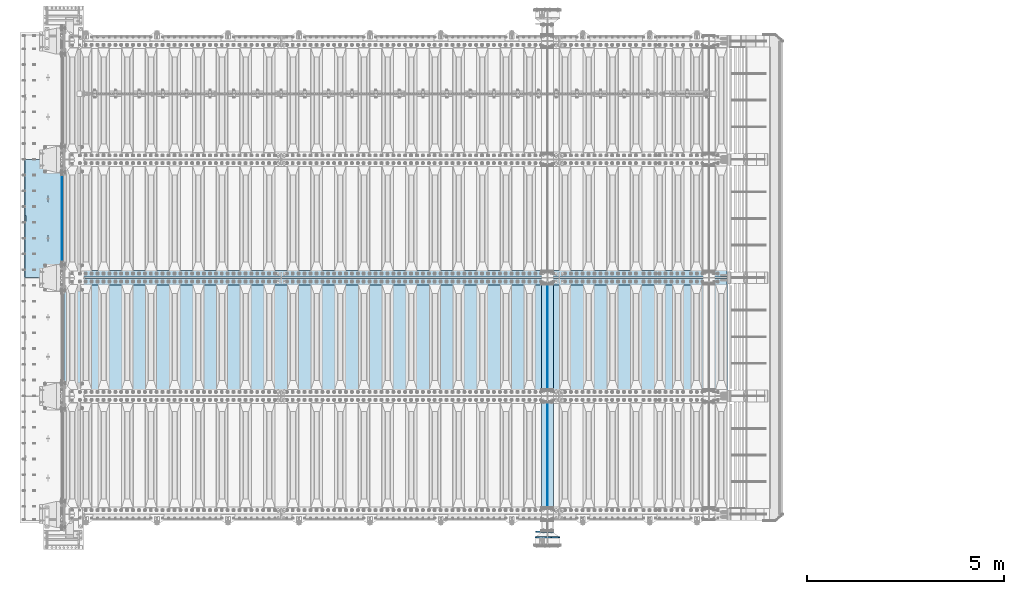
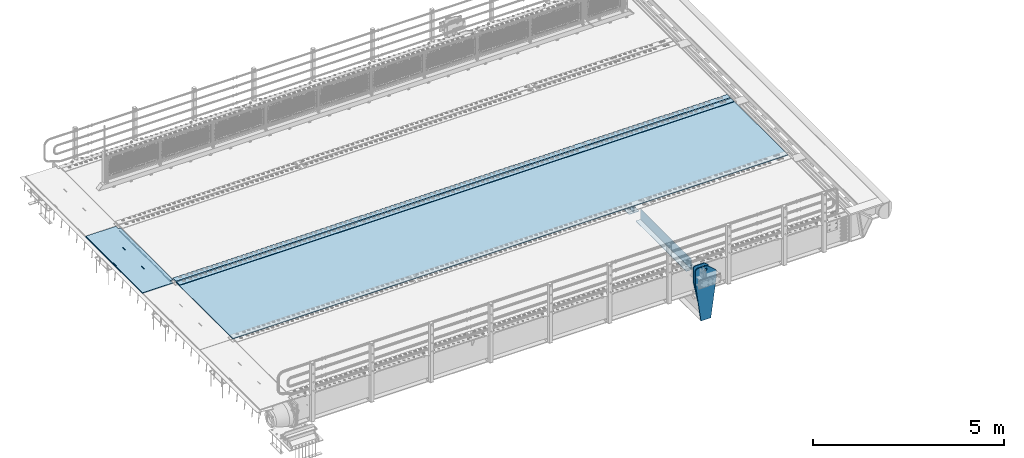
# One storey, part 198 of 257: 11 plates.
"""IFC2X3 building model written with IfcOpenShell, lengths in millimetres."""

from ifc_helpers import new_model, si_unit, frame, origin_with_axes, place, context, subcontext, project, spatial, faceted_brep, material, type_object, element, save


model = new_model("IFC2X3")

# Units and contexts
model_context = context("Model", 3, precision=1e-05, world=origin_with_axes())
body_context = subcontext(model_context, "Body", "Model", "MODEL_VIEW")
ifc_project = project(units=[si_unit("LENGTHUNIT", "METRE", prefix="MILLI"), si_unit("AREAUNIT", "SQUARE_METRE"), si_unit("VOLUMEUNIT", "CUBIC_METRE"), si_unit("MASSUNIT", "GRAM", prefix="KILO"), si_unit("TIMEUNIT", "SECOND"), si_unit("PLANEANGLEUNIT", "RADIAN"), si_unit("SOLIDANGLEUNIT", "STERADIAN"), si_unit("THERMODYNAMICTEMPERATUREUNIT", "DEGREE_CELSIUS"), si_unit("LUMINOUSINTENSITYUNIT", "LUMEN")], contexts=[model_context])

# Site, building, storey
site_placement = place(None, origin_with_axes())
site = spatial("IfcSite", under=ifc_project, at=site_placement, CompositionType="ELEMENT")
building_placement = place(site_placement, origin_with_axes())
building = spatial("IfcBuilding", under=site, at=building_placement, Name="Standard", CompositionType="ELEMENT")
storey_placement = place(building_placement, origin_with_axes())
storey = spatial("IfcBuildingStorey", under=building, at=storey_placement, Name="Undefined", CompositionType="ELEMENT", Elevation=0.0)

# Plates
ifc_material_1 = material(Name="STEEL/S355N")
plate_type_1 = type_object("IfcPlateType", PredefinedType="NOTDEFINED")
plate_1_placement = place(storey_placement, frame((42392.5, 8845.00009940825, -36.0014545213866), z_axis=(0.0, -0.999999999987744, -4.95099999993769e-06), x_axis=(0.0, 4.9510000093107e-06, -0.999999999987744)))
element("IfcPlate", 1, at=plate_1_placement, inside=storey, type_object=plate_type_1, material=ifc_material_1, context=body_context, shape_type="Brep", body=[
    faceted_brep([(7.105427357601e-15, -7.5, 0.0), (-1.24849464100407e-10, -7.5, 70.0), (-1.24849464100407e-10, 7.5, 70.0), (7.105427357601e-15, 7.5, 0.0), (-14.9899997711175, -7.5, 70.0), (-14.9899997711175, 7.5, 70.0), (-14.9899997711161, -7.5, 220.0), (-14.9899997711161, 7.5, 220.0), (-3.90826926377486e-10, -7.5, 220.0), (-3.90826926377486e-10, 7.5, 220.0), (-6.56825704936637e-10, -7.5, 370.0), (-6.56825704936637e-10, 7.5, 370.0), (-14.9899997711147, -7.5, 370.0), (-14.9899997711147, 7.5, 370.0), (-14.9899997711133, -7.5, 520.0), (-14.9899997711133, 7.5, 520.0), (-9.24622156617261e-10, -7.5, 520.0), (-9.24622156617261e-10, 7.5, 520.0), (-1.1906067243217e-09, -7.5, 669.999999999999), (-1.1906067243217e-09, 7.5, 669.999999999999), (-14.9899997711119, -7.5, 669.999999999999), (-14.9899997711119, 7.5, 669.999999999999), (-14.9899997711105, -7.5, 820.0), (-14.9899997711105, 7.5, 820.0), (-1.45477230262259e-09, -7.5, 820.0), (-1.45477230262259e-09, 7.5, 820.0), (-1.72258296515793e-09, -7.5, 970.0), (-1.72258296515793e-09, 7.5, 970.0), (-14.9899997711091, -7.5, 970.000000000001), (-14.9899997711091, 7.5, 970.000000000001), (-14.9899997711077, -7.5, 1120.0), (-14.9899997711077, 7.5, 1120.0), (-1.988560427435e-09, -7.5, 1120.0), (-1.988560427435e-09, 7.5, 1120.0), (-2.2545521005668e-09, -7.5, 1270.0), (-2.2545521005668e-09, 7.5, 1270.0), (-14.9899997711063, -7.5, 1270.0), (-14.9899997711063, 7.5, 1270.0), (-14.9899997711048, -7.5, 1420.0), (-14.9899997711048, 7.5, 1420.0), (-2.52235565767478e-09, -7.5, 1420.0), (-2.52235565767478e-09, 7.5, 1420.0), (-2.78834733080657e-09, -7.5, 1570.0), (-2.78834733080657e-09, 7.5, 1570.0), (-14.9899997711034, -7.5, 1570.0), (-14.9899997711034, 7.5, 1570.0), (-14.989999771102, -7.5, 1720.0), (-14.989999771102, 7.5, 1720.0), (-3.05432479308365e-09, -7.5, 1720.0), (-3.05432479308365e-09, 7.5, 1720.0), (-3.32212835019163e-09, -7.5, 1870.0), (-3.32212835019163e-09, 7.5, 1870.0), (-14.9899997711006, -7.5, 1870.0), (-14.9899997711006, 7.5, 1870.0), (-14.9899997710992, -7.5, 2020.0), (-14.9899997710992, 7.5, 2020.0), (-3.58812002332343e-09, -7.5, 2020.0), (-3.58812002332343e-09, 7.5, 2020.0), (-3.85410459102786e-09, -7.5, 2170.0), (-3.85410459102786e-09, 7.5, 2170.0), (-14.9899997710978, -7.5, 2170.0), (-14.9899997710978, 7.5, 2170.0), (-14.9899997710964, -7.5, 2320.0), (-14.9899997710964, 7.5, 2320.0), (-4.12190104270849e-09, -7.5, 2320.0), (-4.12190104270849e-09, 7.5, 2320.0), (-4.38789982126764e-09, -7.5, 2470.0), (-4.38789982126764e-09, 7.5, 2470.0), (-14.9999999999768, -7.5, 2470.0), (-14.9999999999768, 7.5, 2470.0), (-14.9899997710936, -7.5, 2620.0), (-14.9899997710936, 7.5, 2620.0), (-4.65387728354472e-09, -7.5, 2620.0), (-4.65387728354472e-09, 7.5, 2620.0), (-4.77872674764512e-09, -7.5, 2690.0), (-4.77872674764512e-09, 7.5, 2690.0), (25.0100002289071, -7.5, 2690.0), (25.0100002289071, 7.5, 2690.0), (25.0, -7.5, 0.0), (25.0, 7.5, 0.0)], [[[0, 1, 2, 3]], [[1, 4, 5, 2]], [[4, 6, 7, 5]], [[6, 8, 9, 7]], [[8, 10, 11, 9]], [[10, 12, 13, 11]], [[12, 14, 15, 13]], [[14, 16, 17, 15]], [[16, 18, 19, 17]], [[18, 20, 21, 19]], [[20, 22, 23, 21]], [[22, 24, 25, 23]], [[24, 26, 27, 25]], [[26, 28, 29, 27]], [[28, 30, 31, 29]], [[30, 32, 33, 31]], [[32, 34, 35, 33]], [[34, 36, 37, 35]], [[36, 38, 39, 37]], [[38, 40, 41, 39]], [[40, 42, 43, 41]], [[42, 44, 45, 43]], [[44, 46, 47, 45]], [[46, 48, 49, 47]], [[48, 50, 51, 49]], [[50, 52, 53, 51]], [[52, 54, 55, 53]], [[54, 56, 57, 55]], [[56, 58, 59, 57]], [[58, 60, 61, 59]], [[60, 62, 63, 61]], [[62, 64, 65, 63]], [[64, 66, 67, 65]], [[66, 68, 69, 67]], [[68, 70, 71, 69]], [[70, 72, 73, 71]], [[72, 74, 75, 73]], [[74, 76, 77, 75]], [[76, 78, 79, 77]], [[78, 0, 3, 79]], [[5, 7, 9, 11, 13, 15, 17, 19, 21, 23, 25, 27, 29, 31, 33, 35, 37, 39, 41, 43, 45, 47, 49, 51, 53, 55, 57, 59, 61, 63, 65, 67, 69, 71, 73, 75, 77, 79, 3, 2]], [[78, 76, 74, 72, 70, 68, 66, 64, 62, 60, 58, 56, 54, 52, 50, 48, 46, 44, 42, 40, 38, 36, 34, 32, 30, 28, 26, 24, 22, 20, 18, 16, 14, 12, 10, 8, 6, 4, 1, 0]]]),
])
plate_type_2 = type_object("IfcPlateType", PredefinedType="NOTDEFINED")
plate_2_placement = place(storey_placement, frame((42444.9962456697, 8994.99992617284, -1.00001208605641), z_axis=(0.0, -0.999999999987744, -4.95099999993769e-06), x_axis=(-0.999999999879068, -1.00000022173607e-09, -1.55519999981193e-05)))
element("IfcPlate", 2, at=plate_2_placement, inside=storey, type_object=plate_type_2, material=ifc_material_1, context=body_context, shape_type="Brep", body=[
    faceted_brep([(-0.00011158953566337, -5.71507075430855e-05, 2865.00000504124), (15.0002388791545, 15.0, 2865.00008049103), (15.0000104223, 15.0, 125.000079348153), (-0.000225737428991124, 5.71560199540411e-05, 125.000003632548), (999.996459960938, 5.0, 1.81898940354586e-12), (984.996459960938, 15.0, 1.81898940354586e-12), (984.996459730712, 15.0, 2990.0), (999.996459730719, 5.0, 2990.0), (999.996459730719, -5.0, 2990.0), (984.996459730522, -15.0, 2990.0), (984.996459961367, -15.0, 1.81898940354586e-12), (999.996459960938, -4.99999999999848, 1.81898940354586e-12), (959.99952227655, -15.0000000031848, 1560.00000000851), (959.99952227655, 15.0, 1560.00000000851), (960.488957113354, 15.0, 1563.09016995226), (960.488957113354, -15.0000000031888, 1563.09016995226), (961.909352332339, 15.0, 1565.87785253144), (961.909352332339, -15.0000000032008, 1565.87785253143), (964.121669752996, 15.0, 1568.09016995226), (964.121669752996, -15.0000000032196, 1568.09016995226), (966.909352332055, 15.0, 1569.51056517146), (966.909352332063, -15.0000000032433, 1569.51056517146), (969.999522275757, 15.0, 1570.00000000851), (969.999522275757, -15.0000000032698, 1570.00000000851), (973.089692219546, 15.0, 1569.51056517146), (973.089692219553, -15.0000000032963, 1569.51056517146), (975.877374798845, 15.0, 1568.09016995226), (975.877374798838, -15.0000000033202, 1568.09016995226), (978.08969221983, 15.0, 1565.87785253143), (978.089692219837, -15.0000000033393, 1565.87785253143), (979.510087439245, 15.0, 1563.09016995225), (979.510087439245, -15.0000000033517, 1563.09016995225), (979.999522276536, 15.0, 1560.0000000085), (979.999522276536, -15.0000000033561, 1560.0000000085), (979.99952228638, 15.0, 1430.0000000085), (979.999522286387, -15.0000000033654, 1430.0000000085), (979.510087449569, 15.0, 1426.90983006475), (979.510087449569, -15.0000000033615, 1426.90983006475), (978.089692230591, 15.0, 1424.12214748558), (978.089692230584, -15.0000000033495, 1424.12214748558), (975.877374809934, 15.0, 1421.90983006476), (975.877374809934, -15.0000000033307, 1421.90983006476), (973.089692230868, 15.0, 1420.48943484556), (973.089692230868, -15.000000003307, 1420.48943484556), (969.999522287319, 15.0, 1420.00000000851), (969.999522287319, -15.0000000032805, 1420.00000000851), (966.909352343529, 15.0, 1420.48943484556), (966.909352343537, -15.000000003254, 1420.48943484556), (964.121669764252, 15.0, 1421.90983006476), (964.121669764252, -15.00000000323, 1421.90983006476), (961.90935234326, 15.0, 1424.12214748559), (961.90935234326, -15.0000000032109, 1424.12214748559), (960.488957123831, 15.0, 1426.90983006476), (960.488957123831, -15.0000000031986, 1426.90983006476), (959.999522286547, 15.0, 1430.00000000851), (959.999522286547, -15.0000000031942, 1430.00000000851), (-0.000461898962385021, -14.9999999925605, 124.99992819726), (-0.000462055562820751, -14.9999999889596, 2864.99992960654), (75.0002624102563, 15.0, 125.000080471727), (74.999789880254, -15.0, 124.999929601727), (74.9997820615899, -15.0, 4.54747350886464e-13), (75.0002485915829, 15.0, 0.0), (75.0005015106071, 15.0, 2990.0), (75.0000289806048, -15.0, 2990.0), (75.0004911355936, 15.0, 2865.00008054905), (75.0000186055913, -14.999999997918, 2864.99992967905), (395.488957121597, -15.0, 1926.90983006544), (395.488957121597, 15.0, 1926.90983006544), (394.999522284306, 15.0, 1930.00000000919), (394.999522284306, -15.0, 1930.00000000919), (396.909352341019, -15.0, 1924.12214748626), (396.909352341019, 15.0, 1924.12214748626), (399.121669762011, -15.0, 1921.90983006544), (399.121669762018, 15.0, 1921.90983006544), (401.909352341303, -15.0, 1920.48943484623), (401.909352341296, 15.0, 1920.48943484623), (404.999522285085, -15.0, 1920.00000000919), (404.999522285085, 15.0, 1920.00000000919), (408.089692228663, -15.0, 1920.48943484623), (408.089692228663, 15.0, 1920.48943484623), (410.877374807715, -15.0, 1921.90983006543), (410.877374807715, 15.0, 1921.90983006543), (413.089692228379, -15.0, 1924.12214748626), (413.089692228379, 15.0, 1924.12214748626), (414.510087447357, -15.0, 1926.90983006543), (414.510087447357, 15.0, 1926.90983006543), (414.999522284175, -15.0, 1930.00000000918), (414.999522284175, 15.0, 1930.00000000918), (414.999522274302, -15.0, 2060.00000000918), (414.999522274302, 15.0, 2060.00000000918), (414.510087437011, -15.0, 2063.09016995293), (414.510087437011, 15.0, 2063.09016995293), (413.089692217596, -15.0, 2065.87785253211), (413.089692217589, 15.0, 2065.87785253211), (410.877374796597, -15.0, 2068.09016995293), (410.877374796597, 15.0, 2068.09016995293), (408.08969221732, -15.0, 2069.51056517214), (408.08969221732, 15.0, 2069.51056517214), (404.999522273523, -15.0, 2070.00000000919), (404.999522273523, 15.0, 2070.00000000919), (401.909352329829, -15.0, 2069.51056517214), (401.909352329822, 15.0, 2069.51056517214), (399.121669750755, -15.0, 2068.09016995293), (399.121669750763, 15.0, 2068.09016995294), (396.909352330098, -15.0, 2065.87785253211), (396.909352330105, 15.0, 2065.87785253211), (395.48895711112, -15.0, 2063.09016995294), (395.48895711112, 15.0, 2063.09016995294), (394.999522274309, -15.0, 2060.00000000919), (394.999522274309, 15.0, 2060.00000000919), (395.488957188121, -15.0, 1063.09016995158), (396.909352407114, -15.0, 1065.87785253076), (399.121669827771, -15.0, 1068.09016995158), (401.909352406838, -15.0, 1069.51056517079), (404.999522350532, -15.0, 1070.00000000783), (408.089692294328, -15.0, 1069.51056517079), (410.877374873613, -15.0, 1068.09016995158), (413.089692294612, -15.0, 1065.87785253075), (414.510087514012, -15.0, 1063.09016995158), (414.999522351303, -15.0, 1060.00000000783), (414.999522361184, -15.0, 930.000000007827), (414.510087524366, -15.0, 926.90983006408), (413.089692305388, -15.0, 924.122147484907), (410.877374884731, -15.0, 921.909830064084), (408.089692305664, -15.0, 920.489434844884), (404.999522362086, -15.0, 920.000000007836), (401.909352418312, -15.0, 920.489434844885), (399.121669839027, -15.0, 921.909830064088), (396.909352418028, -15.0, 924.122147484913), (395.488957198606, -15.0, 926.909830064087), (394.999522361322, -15.0, 930.000000007837), (394.999522351311, -15.0, 1060.00000000784), (396.909352418028, 15.0, 924.122147484912), (395.488957198606, 15.0, 926.909830064088), (399.121669839027, 15.0, 921.909830064087), (401.909352418304, 15.0, 920.489434844885), (404.999522362086, 15.0, 920.000000007837), (408.089692305664, 15.0, 920.489434844885), (410.877374884731, 15.0, 921.909830064085), (413.089692305388, 15.0, 924.122147484907), (414.510087524366, 15.0, 926.90983006408), (414.999522361184, 15.0, 930.000000007827), (414.999522351303, 15.0, 1060.00000000783), (414.51008751402, 15.0, 1063.09016995158), (413.089692294605, 15.0, 1065.87785253076), (410.877374873613, 15.0, 1068.09016995158), (408.089692294321, 15.0, 1069.51056517079), (404.999522350539, 15.0, 1070.00000000784), (401.909352406838, 15.0, 1069.51056517079), (399.121669827771, 15.0, 1068.09016995158), (396.909352407114, 15.0, 1065.87785253076), (395.488957188121, 15.0, 1063.09016995158), (394.999522351311, 15.0, 1060.00000000784), (394.999522361322, 15.0, 930.000000007837)], [[[0, 1, 2, 3]], [[4, 5, 6, 7]], [[8, 9, 10, 11]], [[12, 13, 14, 15]], [[15, 14, 16, 17]], [[17, 16, 18, 19]], [[19, 18, 20, 21]], [[21, 20, 22, 23]], [[23, 22, 24, 25]], [[25, 24, 26, 27]], [[27, 26, 28, 29]], [[29, 28, 30, 31]], [[31, 30, 32, 33]], [[33, 32, 34, 35]], [[35, 34, 36, 37]], [[37, 36, 38, 39]], [[39, 38, 40, 41]], [[41, 40, 42, 43]], [[43, 42, 44, 45]], [[45, 44, 46, 47]], [[47, 46, 48, 49]], [[49, 48, 50, 51]], [[51, 50, 52, 53]], [[53, 52, 54, 55]], [[55, 54, 13, 12]], [[56, 57, 0, 3]], [[58, 59, 56, 3, 2]], [[60, 59, 58, 61]], [[11, 10, 60, 61, 5, 4]], [[8, 11, 4, 7]], [[62, 63, 9, 8, 7, 6]], [[63, 62, 64, 65]], [[57, 65, 64, 1, 0]], [[66, 67, 68, 69]], [[70, 71, 67, 66]], [[72, 73, 71, 70]], [[74, 75, 73, 72]], [[76, 77, 75, 74]], [[78, 79, 77, 76]], [[80, 81, 79, 78]], [[82, 83, 81, 80]], [[84, 85, 83, 82]], [[86, 87, 85, 84]], [[88, 89, 87, 86]], [[90, 91, 89, 88]], [[92, 93, 91, 90]], [[94, 95, 93, 92]], [[96, 97, 95, 94]], [[98, 99, 97, 96]], [[100, 101, 99, 98]], [[102, 103, 101, 100]], [[104, 105, 103, 102]], [[106, 107, 105, 104]], [[108, 109, 107, 106]], [[69, 68, 109, 108]], [[63, 65, 57, 56, 59, 60, 10, 9], [15, 17, 19, 21, 23, 25, 27, 29, 31, 33, 35, 37, 39, 41, 43, 45, 47, 49, 51, 53, 55, 12], [110, 111, 112, 113, 114, 115, 116, 117, 118, 119, 120, 121, 122, 123, 124, 125, 126, 127, 128, 129, 130, 131], [106, 104, 102, 100, 98, 96, 94, 92, 90, 88, 86, 84, 82, 80, 78, 76, 74, 72, 70, 66, 69, 108]], [[128, 132, 133, 129]], [[127, 134, 132, 128]], [[126, 135, 134, 127]], [[125, 136, 135, 126]], [[124, 137, 136, 125]], [[123, 138, 137, 124]], [[122, 139, 138, 123]], [[121, 140, 139, 122]], [[120, 141, 140, 121]], [[119, 142, 141, 120]], [[118, 143, 142, 119]], [[117, 144, 143, 118]], [[116, 145, 144, 117]], [[115, 146, 145, 116]], [[114, 147, 146, 115]], [[113, 148, 147, 114]], [[112, 149, 148, 113]], [[111, 150, 149, 112]], [[110, 151, 150, 111]], [[131, 152, 151, 110]], [[130, 153, 152, 131]], [[129, 133, 153, 130]], [[64, 62, 6, 5, 61, 58, 2, 1], [50, 48, 46, 44, 42, 40, 38, 36, 34, 32, 30, 28, 26, 24, 22, 20, 18, 16, 14, 13, 54, 52], [132, 134, 135, 136, 137, 138, 139, 140, 141, 142, 143, 144, 145, 146, 147, 148, 149, 150, 151, 152, 153, 133], [71, 73, 75, 77, 79, 81, 83, 85, 87, 89, 91, 93, 95, 97, 99, 101, 103, 105, 107, 109, 68, 67]]]),
])
plate_type_3 = type_object("IfcPlateType", PredefinedType="NOTDEFINED")
for number, where, z_axis, x_axis in (
    (3, (54550.0, 175.0, -343.0), (0.0, 1.0, 0.0), (1.0, 0.0, 0.0)),
    (4, (54550.0, 3175.0, -343.0), (0.0, 1.0, 0.0), (1.0, 0.0, 0.0)),
):
    element("IfcPlate", number, at=place(storey_placement, frame(where, z_axis=z_axis, x_axis=x_axis)), inside=storey, type_object=plate_type_3, material=ifc_material_1, context=body_context, shape_type="Brep", body=[
        faceted_brep([(0.0, -7.0, 0.0), (0.0, -7.0, 2650.0), (0.0, 7.0, 2650.0), (0.0, 7.0, 0.0), (300.0, -7.0, 2650.0), (300.0, 7.0, 2650.0), (300.0, -7.0, 0.0), (300.0, 7.0, 0.0)], [[[0, 1, 2, 3]], [[1, 4, 5, 2]], [[4, 6, 7, 5]], [[6, 0, 3, 7]], [[5, 7, 3, 2]], [[6, 4, 1, 0]]]),
    ])
plate_type_4 = type_object("IfcPlateType", PredefinedType="NOTDEFINED")
for number, where, z_axis, x_axis in (
    (5, (54700.0, 2825.0, 0.0), (0.0, 0.0, -1.0), (0.0, -1.0, 0.0)),
    (6, (54700.0, 5825.0, 0.0), (0.0, 0.0, -1.0), (0.0, -1.0, 0.0)),
):
    element("IfcPlate", number, at=place(storey_placement, frame(where, z_axis=z_axis, x_axis=x_axis)), inside=storey, type_object=plate_type_4, material=ifc_material_1, context=body_context, shape_type="Brep", body=[
        faceted_brep([(0.0, -5.0, 0.0), (0.0, -5.0, 336.0), (0.0, 5.0, 336.0), (0.0, 5.0, 0.0), (2650.0, -5.0, 336.0), (2650.0, 5.0, 336.0), (2650.0, -5.0, 0.0), (2650.0, 5.0, 0.0)], [[[0, 1, 2, 3]], [[1, 4, 5, 2]], [[4, 6, 7, 5]], [[6, 0, 3, 7]], [[5, 7, 3, 2]], [[6, 4, 1, 0]]]),
    ])
ifc_material_2 = material(Name="STEEL/S235JR")
plate_type_5 = type_object("IfcPlateType", PredefinedType="NOTDEFINED")
for number, where, z_axis, x_axis in (
    (7, (59257.0, 6015.0, 20.0), (-1.0, 0.0, 0.0), (0.0, 1.0, 0.0)),
    (8, (59257.0, 5815.0, 20.0), (-1.0, 0.0, 0.0), (0.0, 1.0, 0.0)),
):
    element("IfcPlate", number, at=place(storey_placement, frame(where, z_axis=z_axis, x_axis=x_axis)), inside=storey, type_object=plate_type_5, material=ifc_material_2, context=body_context, shape_type="Brep", body=[
        faceted_brep([(0.0, -6.0, 0.0), (0.0, -6.0, 16787.0), (0.0, 6.0, 16787.0), (0.0, 6.0, 0.0), (170.0, -6.0, 16787.0), (170.0, 6.0, 16787.0), (170.0, -6.0, 0.0), (170.0, 6.0, 0.0)], [[[0, 1, 2, 3]], [[1, 4, 5, 2]], [[4, 6, 7, 5]], [[6, 0, 3, 7]], [[5, 7, 3, 2]], [[6, 4, 1, 0]]]),
    ])
plate_type_6 = type_object("IfcPlateType", PredefinedType="NOTDEFINED")
plate_3_placement = place(storey_placement, frame((42460.0, 5995.0, 7.0), z_axis=(1.0, 0.0, 0.0), x_axis=(0.0, -1.0, 0.0)))
element("IfcPlate", 9, at=plate_3_placement, inside=storey, type_object=plate_type_6, material=ifc_material_1, context=body_context, shape_type="Brep", body=[
    faceted_brep([(0.0, -7.0, 0.0), (-2.96859070658684e-09, -7.0, 16807.0), (-2.96859070658684e-09, 7.0, 16807.0), (0.0, 7.0, 0.0), (2990.0, -7.0, 16807.0), (2990.0, 7.0, 16807.0), (2990.0, -7.0, 0.0), (2990.0, 7.0, 0.0)], [[[0, 1, 2, 3]], [[1, 4, 5, 2]], [[4, 6, 7, 5]], [[6, 0, 3, 7]], [[5, 7, 3, 2]], [[6, 4, 1, 0]]]),
])
plate_type_7 = type_object("IfcPlateType", PredefinedType="NOTDEFINED")
plate_4_placement = place(storey_placement, frame((54860.0000000139, -439.999999995846, -945.000019543352), z_axis=(-0.901283188008789, 0.0, 0.433230441004224), x_axis=(-0.433230441004227, 0.0, -0.901283188008787)))
element("IfcPlate", 10, at=plate_4_placement, inside=storey, type_object=plate_type_7, material=ifc_material_1, context=body_context, shape_type="Brep", body=[
    faceted_brep([(22.0942403398949, -14.9999999999964, 175.225838688071), (22.0942403398949, 15.0000000000036, 175.225838688071), (270.84838927841, 15.0, 55.6542422352868), (270.84838927841, -15.0, 55.6542422352868), (15.5957837248279, -14.9999999999964, 161.706590867943), (15.5957837248279, 15.0000000000036, 161.706590867943), (264.349935292787, -15.0, 42.1349931512304), (264.349935292787, 15.0, 42.1349931512304), (244.096420288082, -15.0, 2.3283064365387e-10), (244.096420288082, 15.0, 2.3283064365387e-10), (0.0, -15.0, 0.0), (0.0, 15.0, 0.0), (-976.801818847656, -15.0, 469.530853271484), (-976.801818847656, 15.0, 469.530853271484), (-1005.61098604241, -15.0000000000001, 584.572481266798), (-1005.61098604242, 14.9999999999999, 584.57248126679), (-1008.62084772101, -15.0000000000001, 603.379189822284), (-1008.62084772102, 14.9999999999999, 603.379189822284), (-1008.34151554685, -15.0, 622.423179098521), (-1008.34151554685, 15.0, 622.423179098521), (-1004.78136374958, -15.0, 641.133520442199), (-1004.78136374958, 15.0, 641.133520442207), (-998.047107283011, -15.0, 658.949268252029), (-998.047107283011, 15.0, 658.949268252029), (-903.393044122815, -15.0, 855.865689234553), (-903.393044122815, 15.0, 855.865689234553), (-891.965944990745, -15.0, 873.346279725985), (-891.965944990745, 15.0, 873.346279725985), (-876.403904176859, -15.0, 887.273681644809), (-876.403904176859, 15.0, 887.273681644809), (-857.767449567895, -15.0, 896.698765098503), (-857.767449567895, 15.0, 896.698765098503), (-837.326625373324, -15.0, 900.979225908755), (-837.326625373324, 15.0, 900.979225908755), (-816.474440668655, -15.0, 899.823357601344), (-816.474440668655, 15.0, 899.823357601344), (-796.63193808197, -15.0, 893.309930730415), (-796.63193808197, 15.0, 893.309930730415), (-427.105804443356, -15.0, 715.685363769531), (-427.105804443359, 15.0, 715.685363769531), (138.633743286129, -15.0, 288.410614013665), (138.633743286129, 15.0, 288.410614013665), (291.101898193356, -15.0, 97.7892227172852), (291.101898193356, 15.0, 97.7892227172852), (-886.32402569419, -14.9999999999945, 572.182288694887), (-886.32402569419, 15.0000000000055, 572.182288694887), (-901.776420283964, 15.0000000000055, 569.989346058675), (-901.776420283964, -14.9999999999945, 569.989346058675), (-872.887077419415, -14.9999999999945, 580.121678912335), (-872.887077419415, 15.0000000000055, 580.121678912335), (-863.511229028234, -14.9999999999945, 592.598816521153), (-863.511229028234, 15.0000000000055, 592.598816521153), (-859.623868445935, -14.9999999999945, 607.714170425941), (-859.623868445935, 15.0000000000055, 607.714170425941), (-861.81681108215, -14.9999999999945, 623.166565015716), (-861.81681108215, 15.0000000000055, 623.166565015716), (-869.756201299595, -14.9999999999945, 636.603513290502), (-869.756201299595, 15.0000000000055, 636.603513290502), (-882.23333890842, -14.9999999999945, 645.979361681682), (-882.23333890842, 15.0000000000055, 645.979361681682), (-897.348692813208, -14.9999999999945, 649.866722263985), (-897.348692813208, 15.0000000000055, 649.866722263985), (-912.801087402986, -14.9999999999945, 647.673779627759), (-912.801087402986, 15.0000000000055, 647.673779627759), (-926.238035677761, -14.9999999999945, 639.734389410318), (-926.238035677761, 15.0000000000055, 639.734389410318), (-935.613884068938, -14.9999999999945, 627.257251801493), (-935.613884068938, 15.0000000000055, 627.257251801493), (-939.501244651241, -14.9999999999945, 612.141897896712), (-939.501244651241, 15.0000000000055, 612.141897896712), (-937.308302015026, -14.9999999999945, 596.68950330693), (-937.308302015026, 15.0000000000055, 596.68950330693), (-929.368911797577, -14.9999999999945, 583.252555032159), (-929.368911797577, 15.0000000000055, 583.252555032159), (-916.891774188756, -14.9999999999945, 573.876706640978), (-916.891774188756, 15.0000000000055, 573.876706640978), (-844.133640483451, 15.0, 583.284362042767), (-843.858297567211, 15.0, 588.251621173127), (-847.175983338977, 15.0, 591.958700631352), (-852.143242469345, 15.0, 592.234043547585), (-855.850321927563, 15.0, 588.916357775823), (-856.125664843803, 15.0, 583.949098645455), (-852.807979072033, 15.0, 580.242019187237), (-847.840719941669, 15.0, 579.966676270997), (-847.840719941669, -15.0, 579.966676270997), (-852.807979072033, -15.0, 580.242019187237), (-844.133640483451, -15.0, 583.284362042767), (-843.858297567211, -15.0, 588.251621173127), (-847.175983338977, -15.0, 591.958700631352), (-852.143242469345, -15.0, 592.234043547585), (-855.850321927563, -15.0, 588.916357775823), (-856.125664843803, -15.0, 583.949098645455)], [[[0, 1, 2, 3]], [[4, 5, 1, 0]], [[6, 7, 5, 4]], [[8, 9, 7, 6]], [[8, 10, 11, 9]], [[10, 12, 13, 11]], [[12, 14, 15, 13]], [[14, 16, 17, 15]], [[16, 18, 19, 17]], [[18, 20, 21, 19]], [[20, 22, 23, 21]], [[22, 24, 25, 23]], [[24, 26, 27, 25]], [[26, 28, 29, 27]], [[28, 30, 31, 29]], [[30, 32, 33, 31]], [[32, 34, 35, 33]], [[34, 36, 37, 35]], [[36, 38, 39, 37]], [[38, 40, 41, 39]], [[40, 42, 43, 41]], [[43, 42, 3, 2]], [[44, 45, 46, 47]], [[48, 49, 45, 44]], [[50, 51, 49, 48]], [[52, 53, 51, 50]], [[54, 55, 53, 52]], [[56, 57, 55, 54]], [[58, 59, 57, 56]], [[60, 61, 59, 58]], [[62, 63, 61, 60]], [[64, 65, 63, 62]], [[66, 67, 65, 64]], [[68, 69, 67, 66]], [[70, 71, 69, 68]], [[72, 73, 71, 70]], [[74, 75, 73, 72]], [[47, 46, 75, 74]], [[9, 11, 13, 15, 17, 19, 21, 23, 25, 27, 29, 31, 33, 35, 37, 39, 41, 43, 2, 1, 5, 7], [76, 77, 78, 79, 80, 81, 82, 83], [45, 49, 51, 53, 55, 57, 59, 61, 63, 65, 67, 69, 71, 73, 75, 46]], [[84, 83, 82, 85]], [[86, 76, 83, 84]], [[87, 77, 76, 86]], [[88, 78, 77, 87]], [[89, 79, 78, 88]], [[90, 80, 79, 89]], [[91, 81, 80, 90]], [[85, 82, 81, 91]], [[3, 42, 40, 38, 36, 34, 32, 30, 28, 26, 24, 22, 20, 18, 16, 14, 12, 10, 8, 6, 4, 0], [90, 89, 88, 87, 86, 84, 85, 91], [70, 68, 66, 64, 62, 60, 58, 56, 54, 52, 50, 48, 44, 47, 74, 72]]]),
])
plate_type_8 = type_object("IfcPlateType", PredefinedType="NOTDEFINED")
plate_5_placement = place(storey_placement, frame((54850.0, -579.999999995798, -1470.00001953686), z_axis=(0.0, 0.0, 1.0), x_axis=(-1.0, 0.0, 0.0)))
element("IfcPlate", 11, at=plate_5_placement, inside=storey, type_object=plate_type_8, material=ifc_material_1, context=body_context, shape_type="Brep", body=[
    faceted_brep([(113.044818699549, -14.9999999999982, 1615.3073372946), (113.044818699549, 15.0, 1615.3073372946), (121.715728752541, 15.0, 1628.28427124746), (121.715728752541, -14.9999999999982, 1628.28427124746), (134.692662705398, 15.0, 1636.95518130045), (134.692662705398, -14.9999999999982, 1636.95518130045), (150.0, 15.0, 1640.0), (150.0, -14.9999999999982, 1640.0), (165.307337294602, 15.0, 1636.95518130045), (165.307337294602, -14.9999999999982, 1636.95518130045), (178.284271247459, 15.0, 1628.28427124746), (178.284271247459, -14.9999999999982, 1628.28427124746), (186.955181300451, 15.0, 1615.3073372946), (186.955181300451, -14.9999999999982, 1615.3073372946), (190.0, 15.0, 1600.0), (190.0, -14.9999999999982, 1600.0), (186.955181300451, 15.0, 1584.6926627054), (186.955181300451, -14.9999999999982, 1584.6926627054), (178.284271247459, 15.0, 1571.71572875254), (178.284271247459, -14.9999999999982, 1571.71572875254), (165.307337294602, 15.0, 1563.04481869955), (165.307337294602, -14.9999999999982, 1563.04481869955), (150.0, 15.0, 1560.0), (150.0, -14.9999999999982, 1560.0), (134.692662705398, 15.0, 1563.04481869955), (134.692662705398, -14.9999999999982, 1563.04481869955), (121.715728752541, 15.0, 1571.71572875254), (121.715728752541, -14.9999999999982, 1571.71572875254), (113.044818699549, 15.0, 1584.6926627054), (113.044818699549, -14.9999999999982, 1584.6926627054), (110.0, 15.0, 1600.0), (110.0, -14.9999999999982, 1600.0), (300.0, -15.0, 0.0), (0.0, -15.0, 0.0), (0.0, 15.0, 0.0), (300.0, 15.0, 0.0), (462.5, -15.0, 1210.0), (462.5, 15.0, 1210.0), (462.5, -15.0, 1630.0), (462.5, 15.0, 1630.0), (459.774066103128, -15.0, 1650.7055236082), (459.774066103128, 15.0, 1650.7055236082), (451.782032302755, -15.0, 1670.0), (451.782032302755, 15.0, 1670.0), (439.068542494926, -15.0, 1686.56854249492), (439.068542494926, 15.0, 1686.56854249492), (422.5, -15.0, 1699.28203230276), (422.5, 15.0, 1699.28203230276), (403.205523608201, -15.0, 1707.27406610313), (403.205523608201, 15.0, 1707.27406610313), (382.5, -15.0, 1710.0), (382.5, 15.0, 1710.0), (151.788081037077, -15.0, 1710.0), (151.788081037077, 15.0, 1710.0), (132.694887325029, -15.0, 1708.33028179541), (132.694887325029, 15.0, 1708.33028179541), (114.181334578883, -15.0, 1703.37181734316), (114.181334578883, 15.0, 1703.37181734316), (96.8094667268524, -15.0, 1695.27513824985), (96.8094667268524, 15.0, 1695.27513824985), (81.1066678416755, -15.0, 1684.28604765144), (81.1066678416755, 15.0, 1684.28604765144), (-162.5, -15.0, 1480.0), (-162.5, 15.0, 1480.0), (-162.5, -15.0, 1210.0), (-162.5, 15.0, 1210.0), (150.0, -15.0, 1551.5), (154.596194077712, -15.0, 1549.59619407771), (156.5, -15.0, 1545.0), (154.596194077712, -15.0, 1540.40380592229), (150.0, -15.0, 1538.5), (145.403805922288, -15.0, 1540.40380592229), (143.5, -15.0, 1545.0), (145.403805922288, -15.0, 1549.59619407771), (150.0, 15.0, 1538.5), (145.403805922288, 15.0, 1540.40380592229), (154.596194077712, 15.0, 1540.40380592229), (156.5, 15.0, 1545.0), (154.596194077712, 15.0, 1549.59619407771), (150.0, 15.0, 1551.5), (145.403805922288, 15.0, 1549.59619407771), (143.5, 15.0, 1545.0)], [[[0, 1, 2, 3]], [[3, 2, 4, 5]], [[5, 4, 6, 7]], [[7, 6, 8, 9]], [[9, 8, 10, 11]], [[11, 10, 12, 13]], [[13, 12, 14, 15]], [[15, 14, 16, 17]], [[17, 16, 18, 19]], [[19, 18, 20, 21]], [[21, 20, 22, 23]], [[23, 22, 24, 25]], [[25, 24, 26, 27]], [[27, 26, 28, 29]], [[29, 28, 30, 31]], [[31, 30, 1, 0]], [[32, 33, 34, 35]], [[36, 32, 35, 37]], [[38, 36, 37, 39]], [[40, 38, 39, 41]], [[42, 40, 41, 43]], [[44, 42, 43, 45]], [[46, 44, 45, 47]], [[48, 46, 47, 49]], [[50, 48, 49, 51]], [[52, 50, 51, 53]], [[54, 52, 53, 55]], [[56, 54, 55, 57]], [[58, 56, 57, 59]], [[60, 58, 59, 61]], [[62, 60, 61, 63]], [[64, 62, 63, 65]], [[33, 64, 65, 34]], [[32, 36, 38, 40, 42, 44, 46, 48, 50, 52, 54, 56, 58, 60, 62, 64, 33], [3, 5, 7, 9, 11, 13, 15, 17, 19, 21, 23, 25, 27, 29, 31, 0], [66, 67, 68, 69, 70, 71, 72, 73]], [[70, 74, 75, 71]], [[69, 76, 74, 70]], [[68, 77, 76, 69]], [[67, 78, 77, 68]], [[66, 79, 78, 67]], [[73, 80, 79, 66]], [[72, 81, 80, 73]], [[71, 75, 81, 72]], [[63, 61, 59, 57, 55, 53, 51, 49, 47, 45, 43, 41, 39, 37, 35, 34, 65], [26, 24, 22, 20, 18, 16, 14, 12, 10, 8, 6, 4, 2, 1, 30, 28], [74, 76, 77, 78, 79, 80, 81, 75]]]),
])

save(model, "model.ifc")
